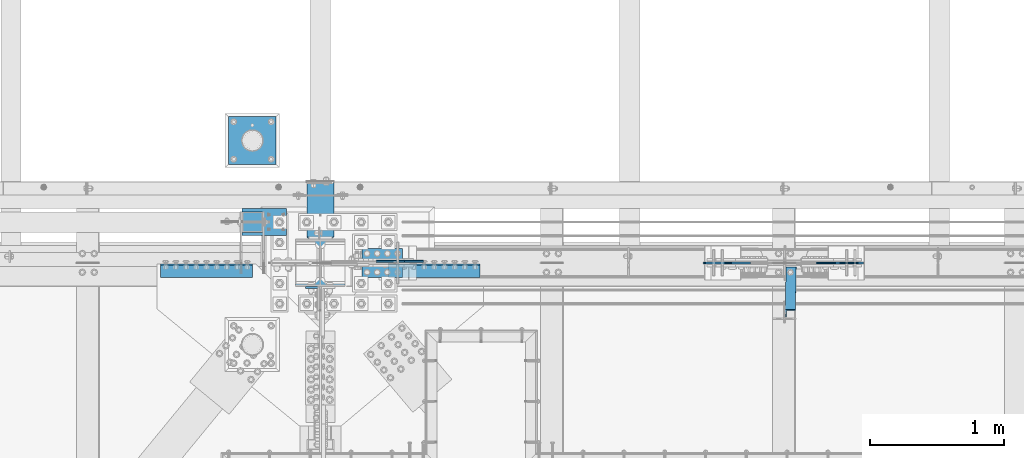
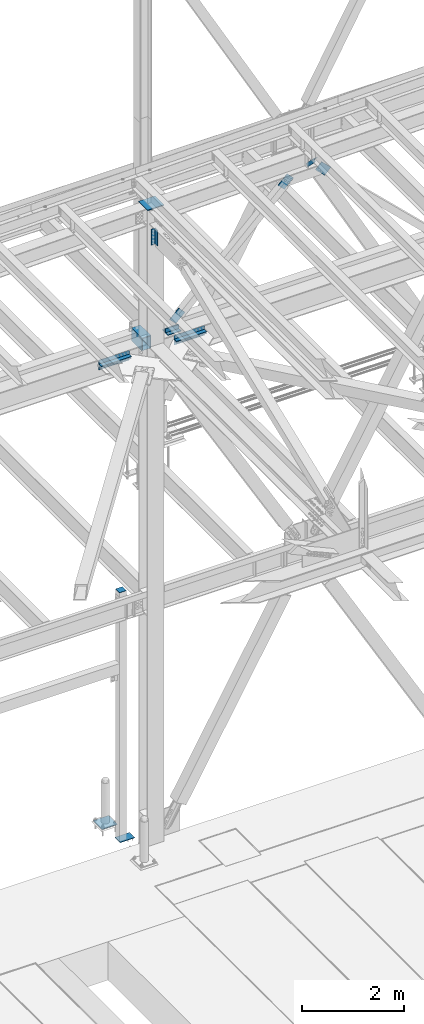
# One storey, part 2508 of 3843: 12 beams, 4 members, 11 elements without a shape of their own.
"""IFC2X3 building model written with IfcOpenShell, lengths in millimetres."""

import ifcopenshell
import ifcopenshell.guid

model = None  # the IFC model being written
_history = None  # IfcOwnerHistory: only IFC2X3 demands one
_inside = {}  # id of a spatial element -> (the spatial element, [elements in it])
_under = {}  # id of a project, library or spatial element -> (it, [spatial elements below it])
_declared = {}  # id of a project -> (the project, [libraries it declares])
_typed = {}  # id of a type object -> (the type object, [elements of that type])
_made_of = {}  # id of a material, layer set ... -> (it, [elements and type objects made of it])


def new_model(schema):
    """Start an empty IFC model of exactly this schema.

    Asked for "IFC4X3", IfcOpenShell would pick the latest addendum, in which some entities
    have other attributes; the version numbers below select the first issue.
    IFC2X3 requires an IfcOwnerHistory on every rooted entity: one is made here for all.
    """
    global model, _history
    if schema == "IFC4X3":
        model = ifcopenshell.file(schema_version=(4, 3, 0, 0))
    else:
        model = ifcopenshell.file(schema=schema)
    _inside.clear()
    _under.clear()
    _declared.clear()
    _typed.clear()
    _made_of.clear()
    _history = None
    if model.schema == "IFC2X3":
        org = make("IfcOrganization", Name="unknown")
        user = make(
            "IfcPersonAndOrganization",
            ThePerson=make("IfcPerson", FamilyName="unknown"),
            TheOrganization=org,
        )
        app = make(
            "IfcApplication",
            ApplicationDeveloper=org,
            Version="unknown",
            ApplicationFullName="unknown",
            ApplicationIdentifier="unknown",
        )
        _history = make(
            "IfcOwnerHistory",
            OwningUser=user,
            OwningApplication=app,
            ChangeAction="ADDED",
            CreationDate=0,
        )
    return model


def make(cls, **values):
    """One entity of the class cls with the attributes given. An attribute that is None is left unset."""
    return model.create_entity(
        cls, **{name: value for name, value in values.items() if value is not None}
    )


def rooted(cls, **values):
    """An entity with a GlobalId (a new one), such as an element, a storey or a relation."""
    return make(cls, GlobalId=ifcopenshell.guid.new(), OwnerHistory=_history, **values)


def si_unit(unit_type, name, prefix=None):
    """IfcSIUnit, for example si_unit("LENGTHUNIT", "METRE", prefix="MILLI")."""
    return make("IfcSIUnit", UnitType=unit_type, Prefix=prefix, Name=name)


def assignment(units):
    """IfcUnitAssignment: the units of a project."""
    return None if units is None else make("IfcUnitAssignment", Units=units)


def point(xyz):
    """IfcCartesianPoint."""
    return None if xyz is None else make("IfcCartesianPoint", Coordinates=xyz)


def direction(xyz):
    """IfcDirection."""
    return None if xyz is None else make("IfcDirection", DirectionRatios=xyz)


def frame(location, z_axis=None, x_axis=None):
    """IfcAxis2Placement3D, a coordinate frame: its origin and axes. An axis left out is left unset."""
    return make(
        "IfcAxis2Placement3D",
        Location=point(location),
        Axis=direction(z_axis),
        RefDirection=direction(x_axis),
    )


def origin_with_axes():
    """The frame at (0, 0, 0) with the z axis (0, 0, 1) and the x axis (1, 0, 0) written out."""
    return frame((0.0, 0.0, 0.0), z_axis=(0.0, 0.0, 1.0), x_axis=(1.0, 0.0, 0.0))


def place(relative_to, where):
    """IfcLocalPlacement: puts the frame where relative to a parent placement (None: the world)."""
    return make(
        "IfcLocalPlacement", PlacementRelTo=relative_to, RelativePlacement=where
    )


def context(
    kind, dimensions, precision=None, world=None, true_north=None, identifier=None
):
    """IfcGeometricRepresentationContext, for example the 3D "Model" context."""
    return make(
        "IfcGeometricRepresentationContext",
        ContextIdentifier=identifier,
        ContextType=kind,
        CoordinateSpaceDimension=dimensions,
        Precision=precision,
        WorldCoordinateSystem=world,
        TrueNorth=true_north,
    )


def subcontext(parent, identifier, kind, view, scale=None):
    """IfcGeometricRepresentationSubContext, for example "Body" below "Model"."""
    return make(
        "IfcGeometricRepresentationSubContext",
        ContextIdentifier=identifier,
        ContextType=kind,
        ParentContext=parent,
        TargetScale=scale,
        TargetView=view,
    )


def project(units=None, contexts=None):
    """IfcProject with its units and contexts."""
    return rooted(
        "IfcProject",
        Name="project",
        RepresentationContexts=contexts,
        UnitsInContext=assignment(units),
    )


def spatial(cls, under=None, at=None, **own):
    """A site, building, storey or space (cls), placed at a placement, below another one or the project."""
    s = rooted(cls, ObjectPlacement=at, **own)
    if under is not None:
        _under.setdefault(under.id(), (under, []))[1].append(s)
    return s


def faces_of(points, faces, orient=None, outer=None):
    """IfcFace entities. A face is a list of loops; a loop is a list of indices into points, from 0.

    orient and outer hold one flag for each loop. By default every Orientation is true, the
    first loop of a face is its IfcFaceOuterBound and the others are IfcFaceBound.
    """
    made = []
    for i, loops in enumerate(faces):
        bounds = []
        for j, loop in enumerate(loops):
            is_outer = j == 0 if outer is None else outer[i][j]
            bounds.append(
                make(
                    "IfcFaceOuterBound" if is_outer else "IfcFaceBound",
                    Bound=make("IfcPolyLoop", Polygon=[points[k] for k in loop]),
                    Orientation=True if orient is None else orient[i][j],
                )
            )
        made.append(make("IfcFace", Bounds=bounds))
    return made


def faceted_brep(points, faces, orient=None, outer=None, voids=None):
    """IfcFacetedBrep: a solid bounded by flat faces; with voids (closed shells), ...WithVoids."""
    shared = [point(p) for p in points]
    hull = make("IfcClosedShell", CfsFaces=faces_of(shared, faces, orient, outer))
    if voids is None:
        return make("IfcFacetedBrep", Outer=hull)
    return make(
        "IfcFacetedBrepWithVoids",
        Outer=hull,
        Voids=[
            make(cls, CfsFaces=faces_of(shared, fs, o, b)) for cls, fs, o, b in voids
        ],
    )


def shape(context_of_items, identifier, shape_type, items):
    """IfcShapeRepresentation: the items that make up one representation, for example the "Body"."""
    return make(
        "IfcShapeRepresentation",
        ContextOfItems=context_of_items,
        RepresentationIdentifier=identifier,
        RepresentationType=shape_type,
        Items=items,
    )


def material(Name=None, Category=None):
    """IfcMaterial."""
    return make("IfcMaterial", Name=Name, Category=Category)


def made_of(thing, what):
    """Note that an element or type object is made of a material, layer set ...; save() writes the relation."""
    if what is not None:
        _made_of.setdefault(what.id(), (what, []))[1].append(thing)
    return thing


def type_object(cls, material=None, **own):
    """A type object (cls), such as IfcWallType, which elements share."""
    return made_of(rooted(cls, **own), material)


def element(
    cls,
    number,
    at=None,
    inside=None,
    cuts=None,
    type_object=None,
    material=None,
    context=None,
    identifier="Body",
    shape_type=None,
    held_by="IfcProductDefinitionShape",
    body=None,
    shapes=None,
    **own,
):
    """One element of the class cls, such as IfcWall. Its Tag is "e" and its number.

    at: its placement. inside: the storey or other place that contains it. cuts: it is an
    opening in that element (IfcRelVoidsElement). A single representation is given by context,
    identifier, shape_type and body (its items); several are given by shapes. held_by: the class
    of the entity that holds the representations. save() writes the other relations.
    """
    e = rooted(cls, Tag="e%d" % number, ObjectPlacement=at, **own)
    if body is not None:
        shapes = [shape(context, identifier, shape_type, body)]
    if shapes is not None:
        e.Representation = make(held_by, Representations=shapes)
    if inside is not None:
        _inside.setdefault(inside.id(), (inside, []))[1].append(e)
    if cuts is not None:
        rooted(
            "IfcRelVoidsElement", RelatingBuildingElement=cuts, RelatedOpeningElement=e
        )
    if type_object is not None:
        _typed.setdefault(type_object.id(), (type_object, []))[1].append(e)
    return made_of(e, material)


def aggregate(whole, parts):
    """IfcRelAggregates: a whole, such as a stair, and the parts it consists of."""
    return rooted("IfcRelAggregates", RelatingObject=whole, RelatedObjects=parts)


def save(model, path):
    """Write the relations noted so far, then the file.

    IfcRelAggregates (storeys below a building ...), IfcRelContainedInSpatialStructure (elements
    in a storey), IfcRelDefinesByType, IfcRelAssociatesMaterial and IfcRelDeclares: one each for
    every whole, place, type object, material and project.
    """
    for whole, parts in _under.values():
        aggregate(whole, parts)
    for where, things in _inside.values():
        rooted(
            "IfcRelContainedInSpatialStructure",
            RelatedElements=things,
            RelatingStructure=where,
        )
    for kind, things in _typed.values():
        rooted("IfcRelDefinesByType", RelatedObjects=things, RelatingType=kind)
    for what, things in _made_of.values():
        rooted("IfcRelAssociatesMaterial", RelatedObjects=things, RelatingMaterial=what)
    for by, libraries in _declared.values():
        rooted("IfcRelDeclares", RelatingContext=by, RelatedDefinitions=libraries)
    model.write(path)


model = new_model("IFC2X3")

# Units and contexts
model_context = context("Model", 3, precision=1e-05, world=origin_with_axes())
body_context = subcontext(model_context, "Body", "Model", "MODEL_VIEW")
ifc_project = project(units=[si_unit("LENGTHUNIT", "METRE", prefix="MILLI"), si_unit("AREAUNIT", "SQUARE_METRE"), si_unit("VOLUMEUNIT", "CUBIC_METRE"), si_unit("MASSUNIT", "GRAM", prefix="KILO"), si_unit("TIMEUNIT", "SECOND"), si_unit("PLANEANGLEUNIT", "RADIAN"), si_unit("SOLIDANGLEUNIT", "STERADIAN"), si_unit("THERMODYNAMICTEMPERATUREUNIT", "DEGREE_CELSIUS"), si_unit("LUMINOUSINTENSITYUNIT", "LUMEN")], contexts=[model_context])

# Site, building, storey
site_placement = place(None, origin_with_axes())
site = spatial("IfcSite", under=ifc_project, at=site_placement, CompositionType="ELEMENT")
building_placement = place(site_placement, origin_with_axes())
building = spatial("IfcBuilding", under=site, at=building_placement, Name="Undefined", CompositionType="ELEMENT")
storey_placement = place(building_placement, origin_with_axes())
storey = spatial("IfcBuildingStorey", under=building, at=storey_placement, Name="Undefined", CompositionType="ELEMENT", Elevation=0.0)

# Assembly, beam
assembly_1_placement = place(storey_placement, origin_with_axes())
assembly_1 = element("IfcElementAssembly", 1, at=assembly_1_placement, inside=storey, Name="TEMPLATE", AssemblyPlace="NOTDEFINED", PredefinedType="RIGID_FRAME")
ifc_material_1 = material(Name="STEEL/A36")
beam_type_1 = type_object("IfcBeamType", PredefinedType="NOTDEFINED")
beam_1_placement = place(assembly_1_placement, frame((48666.4, 93129.1, 30506.9875), z_axis=(0.0, -1.0, 0.0), x_axis=(-1.0, 0.0, 0.0)))
beam_1 = element("IfcBeam", 2, at=beam_1_placement, type_object=beam_type_1, material=ifc_material_1, Name="TEMPLATE", context=body_context, shape_type="Brep", body=[
    faceted_brep([(0.0, 1.58750000000146, -177.800000000003), (0.0, 1.58750000000146, 177.800000000003), (355.600000000006, 1.58750000000146, 177.800000000003), (355.600000000006, 1.58750000000146, -177.800000000003), (0.0, -1.58750000000146, 177.800000000003), (355.600000000006, -1.58750000000146, 177.800000000003), (0.0, -1.58750000000146, -177.800000000003), (355.600000000006, -1.58750000000146, -177.800000000003)], [[[0, 1, 2, 3]], [[1, 4, 5, 2]], [[4, 6, 7, 5]], [[6, 0, 3, 7]], [[5, 7, 3, 2]], [[6, 4, 1, 0]]]),
])
aggregate(assembly_1, [beam_1])

assembly_2_placement = place(storey_placement, origin_with_axes())
assembly_2 = element("IfcElementAssembly", 3, at=assembly_2_placement, inside=storey, Name="ANGLE", AssemblyPlace="NOTDEFINED", PredefinedType="RIGID_FRAME")
ifc_material_2 = material(Name="STEEL/A572-50")
beam_type_2 = type_object("IfcBeamType", Name="L4X4X3/8", PredefinedType="NOTDEFINED")
beam_2_placement = place(assembly_2_placement, frame((49611.7562499999, 92271.8499998457, 42519.6000000013), z_axis=(0.0, 0.0, 1.0), x_axis=(-1.0, 0.0, 0.0)))
beam_2 = element("IfcBeam", 4, at=beam_2_placement, type_object=beam_type_2, material=ifc_material_2, Name="ANGLE", ObjectType="L4X4X3/8", context=body_context, shape_type="Brep", body=[
    faceted_brep([(0.0, 50.8000000000029, -50.8000000000029), (0.0, 50.8000000000029, 50.8000000000029), (304.800000000003, 50.8000000000029, 50.8000000000029), (304.800000000003, 50.8000000000029, -50.8000000000029), (0.0, 41.2750000000015, 50.8000000000029), (304.800000000003, 41.2749999999942, 50.8000000000029), (0.0, 41.2749999999942, -41.2750000000015), (304.800000000003, 41.2749999999942, -41.2750000000015), (0.0, -50.8000000000029, -41.2750000000015), (304.800000000003, -50.8000000000029, -41.2750000000015), (0.0, -50.8000000000029, -50.8000000000029), (304.800000000003, -50.8000000000029, -50.8000000000029)], [[[0, 1, 2, 3]], [[1, 4, 5, 2]], [[4, 6, 7, 5]], [[6, 8, 9, 7]], [[8, 10, 11, 9]], [[10, 0, 3, 11]], [[5, 7, 9, 11, 3, 2]], [[10, 8, 6, 4, 1, 0]]]),
])
aggregate(assembly_2, [beam_2])

assembly_3_placement = place(storey_placement, origin_with_axes())
assembly_3 = element("IfcElementAssembly", 5, at=assembly_3_placement, inside=storey, Name="ANGLE", AssemblyPlace="NOTDEFINED", PredefinedType="RIGID_FRAME")
beam_3_placement = place(assembly_3_placement, frame((49306.9562499999, 92157.5499998457, 42519.6000000013), z_axis=(0.0, 0.0, 1.0), x_axis=(1.0, 0.0, 0.0)))
beam_3 = element("IfcBeam", 6, at=beam_3_placement, type_object=beam_type_2, material=ifc_material_2, Name="ANGLE", ObjectType="L4X4X3/8", context=body_context, shape_type="Brep", body=[
    faceted_brep([(0.0, 50.8000000000029, -50.8000000000029), (0.0, 50.8000000000029, 50.8000000000029), (304.800000000003, 50.8000000000029, 50.8000000000029), (304.800000000003, 50.8000000000029, -50.8000000000029), (0.0, 41.2750000000015, 50.8000000000029), (304.800000000003, 41.2749999999942, 50.8000000000029), (0.0, 41.2749999999942, -41.2750000000015), (304.800000000003, 41.2749999999942, -41.2750000000015), (0.0, -50.8000000000029, -41.2750000000015), (304.800000000003, -50.8000000000029, -41.2750000000015), (0.0, -50.8000000000029, -50.8000000000029), (304.800000000003, -50.8000000000029, -50.8000000000029)], [[[0, 1, 2, 3]], [[1, 4, 5, 2]], [[4, 6, 7, 5]], [[6, 8, 9, 7]], [[8, 10, 11, 9]], [[10, 0, 3, 11]], [[5, 7, 9, 11, 3, 2]], [[10, 8, 6, 4, 1, 0]]]),
])
aggregate(assembly_3, [beam_3])

# Assembly, beams
assembly_4_placement = place(storey_placement, origin_with_axes())
assembly_4 = element("IfcElementAssembly", 7, at=assembly_4_placement, inside=storey, Name="PLATE", AssemblyPlace="NOTDEFINED", PredefinedType="RIGID_FRAME")
beam_type_3 = type_object("IfcBeamType", Name="L4X4X1/2", PredefinedType="NOTDEFINED")
beam_4_placement = place(assembly_4_placement, frame((50190.4000000004, 92157.5500000029, 42297.3500007629), z_axis=(0.0, -1.0, 0.0), x_axis=(-1.0, 0.0, 0.0)))
beam_4 = element("IfcBeam", 8, at=beam_4_placement, type_object=beam_type_3, material=ifc_material_2, Name="ANGLE", ObjectType="L4X4X1/2", context=body_context, shape_type="Brep", body=[
    faceted_brep([(0.0, 50.8000000000029, -50.8000000000029), (0.0, 50.8000000000029, 50.8000000000029), (685.800000000003, 50.8000000000029, 50.8000000000029), (685.800000000003, 50.8000000000029, -50.8000000000029), (0.0, 38.0999999999985, 50.8000000000029), (685.800000000003, 38.0999999999985, 50.8000000000029), (0.0, 38.0999999999985, -38.0999999999985), (685.800000000003, 38.0999999999985, -38.1000000000058), (0.0, -50.8000000000029, -38.1000000000058), (685.800000000003, -50.8000000000029, -38.1000000000058), (0.0, -50.8000000000029, -50.8000000000029), (685.800000000003, -50.8000000000029, -50.8000000000029)], [[[0, 1, 2, 3]], [[1, 4, 5, 2]], [[4, 6, 7, 5]], [[6, 8, 9, 7]], [[8, 10, 11, 9]], [[10, 0, 3, 11]], [[5, 7, 9, 11, 3, 2]], [[10, 8, 6, 4, 1, 0]]]),
])
beam_5_placement = place(assembly_4_placement, frame((49504.6000000004, 92157.5500000029, 42167.175), z_axis=(0.0, -1.0, 0.0), x_axis=(1.0, 0.0, 0.0)))
beam_5 = element("IfcBeam", 9, at=beam_5_placement, type_object=beam_type_3, material=ifc_material_2, Name="ANGLE", ObjectType="L4X4X1/2", context=body_context, shape_type="Brep", body=[
    faceted_brep([(0.0, 50.8000000000029, -50.8000000000029), (0.0, 50.8000000000029, 50.8000000000029), (685.800000000003, 50.8000000000029, 50.8000000000029), (685.800000000003, 50.8000000000029, -50.8000000000029), (0.0, 38.0999999999985, 50.8000000000029), (685.800000000003, 38.0999999999985, 50.8000000000029), (0.0, 38.0999999999985, -38.0999999999985), (685.800000000003, 38.0999999999985, -38.1000000000058), (0.0, -50.8000000000029, -38.1000000000058), (685.800000000003, -50.8000000000029, -38.1000000000058), (0.0, -50.8000000000029, -50.8000000000029), (685.800000000003, -50.8000000000029, -50.8000000000029)], [[[0, 1, 2, 3]], [[1, 4, 5, 2]], [[4, 6, 7, 5]], [[6, 8, 9, 7]], [[8, 10, 11, 9]], [[10, 0, 3, 11]], [[5, 7, 9, 11, 3, 2]], [[10, 8, 6, 4, 1, 0]]]),
])
aggregate(assembly_4, [beam_4, beam_5])

assembly_5_placement = place(storey_placement, origin_with_axes())
assembly_5 = element("IfcElementAssembly", 10, at=assembly_5_placement, inside=storey, Name="PLATE", AssemblyPlace="NOTDEFINED", PredefinedType="RIGID_FRAME")
beam_6_placement = place(assembly_5_placement, frame((48488.6, 92157.5499999973, 42297.35), z_axis=(0.0, -1.0, 0.0), x_axis=(-1.0, 0.0, 0.0)))
beam_6 = element("IfcBeam", 11, at=beam_6_placement, type_object=beam_type_3, material=ifc_material_2, Name="ANGLE", ObjectType="L4X4X1/2", context=body_context, shape_type="Brep", body=[
    faceted_brep([(0.0, 50.8000000000029, -50.8000000000029), (0.0, 50.8000000000029, 50.8000000000029), (685.800000000003, 50.8000000000029, 50.8000000000029), (685.800000000003, 50.8000000000029, -50.8000000000029), (0.0, 38.0999999999985, 50.8000000000029), (685.800000000003, 38.0999999999985, 50.8000000000029), (0.0, 38.0999999999985, -38.0999999999985), (685.800000000003, 38.0999999999985, -38.1000000000058), (0.0, -50.8000000000029, -38.1000000000058), (685.800000000003, -50.8000000000029, -38.1000000000058), (0.0, -50.8000000000029, -50.8000000000029), (685.800000000003, -50.8000000000029, -50.8000000000029)], [[[0, 1, 2, 3]], [[1, 4, 5, 2]], [[4, 6, 7, 5]], [[6, 8, 9, 7]], [[8, 10, 11, 9]], [[10, 0, 3, 11]], [[5, 7, 9, 11, 3, 2]], [[10, 8, 6, 4, 1, 0]]]),
])
beam_7_placement = place(assembly_5_placement, frame((47802.8, 92157.5499999973, 42167.175), z_axis=(0.0, -1.0, 0.0), x_axis=(1.0, 0.0, 0.0)))
beam_7 = element("IfcBeam", 12, at=beam_7_placement, type_object=beam_type_3, material=ifc_material_2, Name="ANGLE", ObjectType="L4X4X1/2", context=body_context, shape_type="Brep", body=[
    faceted_brep([(0.0, 50.8000000000029, -50.8000000000029), (0.0, 50.8000000000029, 50.8000000000029), (685.800000000003, 50.8000000000029, 50.8000000000029), (685.800000000003, 50.8000000000029, -50.8000000000029), (0.0, 38.0999999999985, 50.8000000000029), (685.800000000003, 38.0999999999985, 50.8000000000029), (0.0, 38.0999999999985, -38.0999999999985), (685.800000000003, 38.0999999999985, -38.1000000000058), (0.0, -50.8000000000029, -38.1000000000058), (685.800000000003, -50.8000000000029, -38.1000000000058), (0.0, -50.8000000000029, -50.8000000000029), (685.800000000003, -50.8000000000029, -50.8000000000029)], [[[0, 1, 2, 3]], [[1, 4, 5, 2]], [[4, 6, 7, 5]], [[6, 8, 9, 7]], [[8, 10, 11, 9]], [[10, 0, 3, 11]], [[5, 7, 9, 11, 3, 2]], [[10, 8, 6, 4, 1, 0]]]),
])
aggregate(assembly_5, [beam_6, beam_7])

# Assembly, beam
assembly_6_placement = place(storey_placement, origin_with_axes())
assembly_6 = element("IfcElementAssembly", 13, at=assembly_6_placement, inside=storey, Name="PLATE", AssemblyPlace="NOTDEFINED", PredefinedType="RIGID_FRAME")
beam_8_placement = place(assembly_6_placement, frame((48937.8625000007, 91986.1000000546, 45202.9146634992), z_axis=(0.0, -1.0, 0.0), x_axis=(0.0, 0.0, -1.0)))
beam_8 = element("IfcBeam", 14, at=beam_8_placement, type_object=beam_type_3, material=ifc_material_2, Name="ANGLE", ObjectType="L4X4X1/2", context=body_context, shape_type="Brep", body=[
    faceted_brep([(0.0, 50.8000000000029, -50.8000000000029), (0.0, 50.8000000000029, 50.8000000000029), (381.0, 50.8000000000029, 50.8000000000029), (381.0, 50.8000000000029, -50.8000000000029), (0.0, 38.0999999999985, 50.8000000000029), (381.0, 38.0999999999985, 50.8000000000029), (0.0, 38.0999999999985, -38.0999999999985), (381.0, 38.0999999999985, -38.1000000000058), (0.0, -50.8000000000029, -38.1000000000058), (381.0, -50.8000000000029, -38.1000000000058), (0.0, -50.8000000000029, -50.8000000000029), (381.0, -50.8000000000029, -50.8000000000029)], [[[0, 1, 2, 3]], [[1, 4, 5, 2]], [[4, 6, 7, 5]], [[6, 8, 9, 7]], [[8, 10, 11, 9]], [[10, 0, 3, 11]], [[5, 7, 9, 11, 3, 2]], [[10, 8, 6, 4, 1, 0]]]),
])
aggregate(assembly_6, [beam_8])

# Assembly, member
assembly_7_placement = place(storey_placement, origin_with_axes())
assembly_7 = element("IfcElementAssembly", 15, at=assembly_7_placement, inside=storey, AssemblyPlace="NOTDEFINED", PredefinedType="RIGID_FRAME")
member_type_1 = type_object("IfcMemberType", PredefinedType="NOTDEFINED")
member_1_placement = place(assembly_7_placement, frame((52772.6686429569, 92214.6999998457, 45248.0407054735), z_axis=(0.694768099788301, 0.0, 0.719233819780851), x_axis=(0.719233819780852, 0.0, -0.6947680997883)))
member_1 = element("IfcMember", 16, at=member_1_placement, type_object=member_type_1, material=ifc_material_2, Name="PLATE", context=body_context, shape_type="Brep", body=[
    faceted_brep([(1.74622982740402e-10, 6.35000000000582, -101.600000000195), (-1.67347025126219e-10, 6.35000000000582, 101.600000000151), (292.1000000028, 6.35000000000582, 101.600000000661), (292.100000003156, 6.35000000000582, -101.599999999686), (-1.67347025126219e-10, -6.35000000000582, 101.600000000151), (292.1000000028, -6.35000000000582, 101.600000000661), (1.74622982740402e-10, -6.35000000000582, -101.600000000195), (292.100000003156, -6.35000000000582, -101.599999999686)], [[[0, 1, 2, 3]], [[1, 4, 5, 2]], [[4, 6, 7, 5]], [[6, 0, 3, 7]], [[5, 7, 3, 2]], [[6, 4, 1, 0]]]),
])
aggregate(assembly_7, [member_1])

# Assembly, members
assembly_8_placement = place(storey_placement, origin_with_axes())
assembly_8 = element("IfcElementAssembly", 17, at=assembly_8_placement, inside=storey, AssemblyPlace="NOTDEFINED", PredefinedType="RIGID_FRAME")
member_2_placement = place(assembly_8_placement, frame((52137.7330571896, 92214.6999998457, 45231.6206248538), z_axis=(0.694768099271008, 0.0, -0.719233820280547), x_axis=(-0.719233820280536, 0.0, -0.69476809927102)))
member_2 = element("IfcMember", 18, at=member_2_placement, type_object=member_type_1, material=ifc_material_2, Name="PLATE", context=body_context, shape_type="Brep", body=[
    faceted_brep([(1.74622982740402e-10, 6.35000000000582, -101.600000000195), (-1.67347025126219e-10, 6.35000000000582, 101.600000000151), (292.1000000028, 6.35000000000582, 101.600000000661), (292.100000003156, 6.35000000000582, -101.599999999686), (-1.67347025126219e-10, -6.35000000000582, 101.600000000151), (292.1000000028, -6.35000000000582, 101.600000000661), (1.74622982740402e-10, -6.35000000000582, -101.600000000195), (292.100000003156, -6.35000000000582, -101.599999999686)], [[[0, 1, 2, 3]], [[1, 4, 5, 2]], [[4, 6, 7, 5]], [[6, 0, 3, 7]], [[5, 7, 3, 2]], [[6, 4, 1, 0]]]),
])
member_3_placement = place(assembly_8_placement, frame((49484.7414546216, 92227.3999998457, 42668.8741561462), z_axis=(-0.694768099271023, 0.0, 0.719233820280533), x_axis=(0.71923382028056, 0.0, 0.694768099270995)))
member_3 = element("IfcMember", 19, at=member_3_placement, type_object=member_type_1, material=ifc_material_2, Name="PLATE", context=body_context, shape_type="Brep", body=[
    faceted_brep([(1.74622982740402e-10, 6.35000000000582, -101.600000000195), (-1.67347025126219e-10, 6.35000000000582, 101.600000000151), (292.1000000028, 6.35000000000582, 101.600000000661), (292.100000003156, 6.35000000000582, -101.599999999686), (-1.67347025126219e-10, -6.35000000000582, 101.600000000151), (292.1000000028, -6.35000000000582, 101.600000000661), (1.74622982740402e-10, -6.35000000000582, -101.600000000195), (292.100000003156, -6.35000000000582, -101.599999999686)], [[[0, 1, 2, 3]], [[1, 4, 5, 2]], [[4, 6, 7, 5]], [[6, 0, 3, 7]], [[5, 7, 3, 2]], [[6, 4, 1, 0]]]),
])
aggregate(assembly_8, [member_2, member_3])

# Assembly, member
assembly_9_placement = place(storey_placement, origin_with_axes())
assembly_9 = element("IfcElementAssembly", 20, at=assembly_9_placement, inside=storey, Name="ANGLE", AssemblyPlace="NOTDEFINED", PredefinedType="RIGID_FRAME")
member_type_2 = type_object("IfcMemberType", Name="L3X3X3/8", PredefinedType="NOTDEFINED")
member_4_placement = place(assembly_9_placement, frame((52515.2909337929, 92214.7000001009, 45339.5818199846), z_axis=(0.0149567919892506, -0.707106781418042, -0.706948579492178), x_axis=(-0.014956791999047, -0.707106780955057, 0.706948579955059)))
member_4 = element("IfcMember", 21, at=member_4_placement, type_object=member_type_2, material=ifc_material_2, Name="ANGLE", ObjectType="L3X3X3/8", context=body_context, shape_type="Brep", body=[
    faceted_brep([(531.606218367575, -38.1000000000058, -28.5749999999234), (531.606218367589, -38.1000000000058, -38.099999999903), (531.606218367589, 38.1000000000058, -38.099999999903), (531.606218367582, 38.1000000000058, 38.0999999999158), (531.606218367582, 28.5749999999971, 38.0999999999158), (531.606218367575, 28.5749999999971, -28.5749999999234), (80.7562183701375, 28.5749999999971, 38.0999999999158), (80.7562183701448, 28.5749999999971, -28.5749999999271), (80.7562183701448, -38.1000000000058, -28.5749999999271), (80.7562183701448, -38.1000000000058, -38.099999999903), (80.7562183701448, 38.1000000000058, -38.099999999903), (80.7562183701375, 38.1000000000058, 38.0999999999158)], [[[0, 1, 2, 3, 4, 5]], [[5, 4, 6, 7]], [[0, 5, 7, 8]], [[1, 0, 8, 9]], [[2, 1, 9, 10]], [[3, 2, 10, 11]], [[4, 3, 11, 6]], [[10, 9, 8, 7, 6, 11]]]),
])
aggregate(assembly_9, [member_4])

# Assembly, beam
assembly_10_placement = place(storey_placement, origin_with_axes())
assembly_10 = element("IfcElementAssembly", 22, at=assembly_10_placement, inside=storey, Name="POST", AssemblyPlace="NOTDEFINED", PredefinedType="RIGID_FRAME")
beam_type_4 = type_object("IfcBeamType", PredefinedType="NOTDEFINED")
beam_9_placement = place(assembly_10_placement, frame((48488.6, 92443.3, 36433.125), z_axis=(1.0, 0.0, 0.0), x_axis=(0.0, 1.0, 0.0)))
beam_9 = element("IfcBeam", 23, at=beam_9_placement, type_object=beam_type_4, material=ifc_material_2, Name="PLATE", context=body_context, shape_type="Brep", body=[
    faceted_brep([(0.0, 3.17500000000291, -76.2000000000007), (0.0, 3.17499999999927, 76.1999969482422), (152.399999999994, 3.17500000000291, 76.1999999999971), (152.399999999994, 3.17500000000291, -76.1999999999971), (0.0, -3.17499999999927, 76.1999969482422), (152.399999999994, -3.17500000000291, 76.1999999999971), (0.0, -3.17500000000291, -76.2000000000007), (152.399999999994, -3.17500000000291, -76.1999999999971)], [[[0, 1, 2, 3]], [[1, 4, 5, 2]], [[4, 6, 7, 5]], [[6, 0, 3, 7]], [[5, 7, 3, 2]], [[6, 4, 1, 0]]]),
])

assembly_11_placement = place(storey_placement, origin_with_axes())
assembly_11 = element("IfcElementAssembly", 24, at=assembly_11_placement, inside=storey, Name="COLUMN", AssemblyPlace="NOTDEFINED", PredefinedType="RIGID_FRAME")
ifc_material_3 = material()
beam_type_5 = type_object("IfcBeamType", Name="HSS12X8X3/8", PredefinedType="NOTDEFINED")
beam_10_placement = place(assembly_11_placement, frame((48996.6, 92392.5, 42214.8), z_axis=(0.0, 0.0, 1.0), x_axis=(0.0, 1.0, 0.0)))
beam_10 = element("IfcBeam", 25, at=beam_10_placement, type_object=beam_type_5, material=ifc_material_3, Name="GIRT", ObjectType="HSS12X8X3/8", context=body_context, shape_type="Brep", body=[
    faceted_brep([(15.8750001309381, 101.600000000006, 152.399999999972), (15.8749984899478, 101.600000000006, -152.400000000031), (6.35000000002037, 92.0749999999971, -142.875), (6.35000000002037, 92.0749999999971, 142.875), (15.8749984899478, -101.600000000006, -152.400000000031), (6.35000000002037, -92.0749999999971, -142.875), (15.8750001044536, -101.600000052975, 152.399999973481), (6.35000000002037, -92.0749999999971, 142.875), (425.449999999983, -101.600000000006, 152.400000000001), (425.449999999983, 101.600000000006, 152.400000000001), (425.449999999983, -101.600000000006, -152.400000000001), (425.449999999983, 101.600000000006, -152.400000000001), (425.449999999957, -92.074999999968, 142.874999999971), (425.450000000015, 92.0749999999971, 142.875), (425.450000000015, 92.0749999999971, -142.875), (425.450000000015, -92.0749999999971, -142.875)], [[[0, 1, 2, 3]], [[4, 5, 2, 1]], [[6, 7, 5, 4]], [[8, 9, 0, 6]], [[10, 8, 6, 4]], [[11, 10, 4, 1]], [[9, 11, 1, 0]], [[8, 10, 11, 9], [12, 13, 14, 15]], [[3, 2, 14, 13]], [[2, 5, 15, 14]], [[5, 7, 12, 15]], [[7, 3, 13, 12]], [[0, 3, 7, 6]]]),
])

# Beam
beam_type_6 = type_object("IfcBeamType", PredefinedType="NOTDEFINED")
beam_11_placement = place(assembly_10_placement, frame((48577.5000015259, 92417.9000003815, 30486.35), z_axis=(-1.0, 0.0, 0.0), x_axis=(0.0, 1.0, 0.0)))
beam_11 = element("IfcBeam", 26, at=beam_11_placement, type_object=beam_type_6, material=ifc_material_2, context=body_context, shape_type="Brep", body=[
    faceted_brep([(-4.07453626394272e-10, 6.34999999999854, -165.099999999366), (3.92901711165905e-10, 6.34999999999854, 165.099999999351), (203.199999237055, 6.34999999999854, 165.099999999999), (203.199999237055, 6.34999999999854, -165.099999999999), (3.92901711165905e-10, -6.34999999999854, 165.099999999351), (203.199999237055, -6.34999999999854, 165.099999999999), (-4.07453626394272e-10, -6.34999999999854, -165.099999999366), (203.199999237055, -6.34999999999854, -165.099999999999)], [[[0, 1, 2, 3]], [[1, 4, 5, 2]], [[4, 6, 7, 5]], [[6, 0, 3, 7]], [[5, 7, 3, 2]], [[6, 4, 1, 0]]]),
])

aggregate(assembly_10, [beam_9, beam_11])

beam_type_7 = type_object("IfcBeamType", PredefinedType="NOTDEFINED")
beam_12_placement = place(assembly_11_placement, frame((48996.6, 92036.9, 45669.8844373239), z_axis=(1.0, 0.0, 0.0), x_axis=(0.0, 1.0, 0.0)))
beam_12 = element("IfcBeam", 27, at=beam_12_placement, type_object=beam_type_7, material=ifc_material_2, Name="PLATE", context=body_context, shape_type="Brep", body=[
    faceted_brep([(0.0, 9.52500000000146, -184.150000000001), (0.0, 9.52500000000146, 184.150000000001), (355.600000000006, 9.52500000000146, 184.150000000001), (355.600000000006, 9.52500000000146, -184.150000000001), (0.0, -9.52500000000146, 184.150000000001), (355.600000000006, -9.52500000000146, 184.150000000001), (0.0, -9.52500000000146, -184.150000000001), (355.600000000006, -9.52500000000146, -184.150000000001)], [[[0, 1, 2, 3]], [[1, 4, 5, 2]], [[4, 6, 7, 5]], [[6, 0, 3, 7]], [[5, 7, 3, 2]], [[6, 4, 1, 0]]]),
])

aggregate(assembly_11, [beam_12, beam_10])

save(model, "model.ifc")
